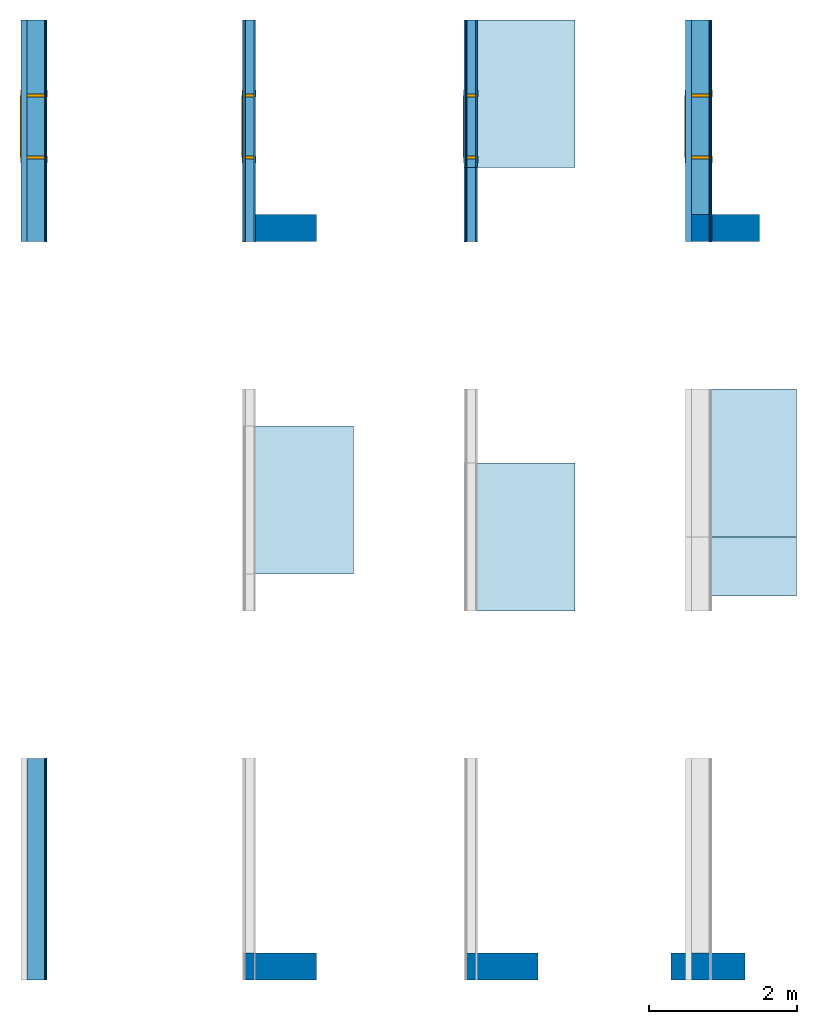
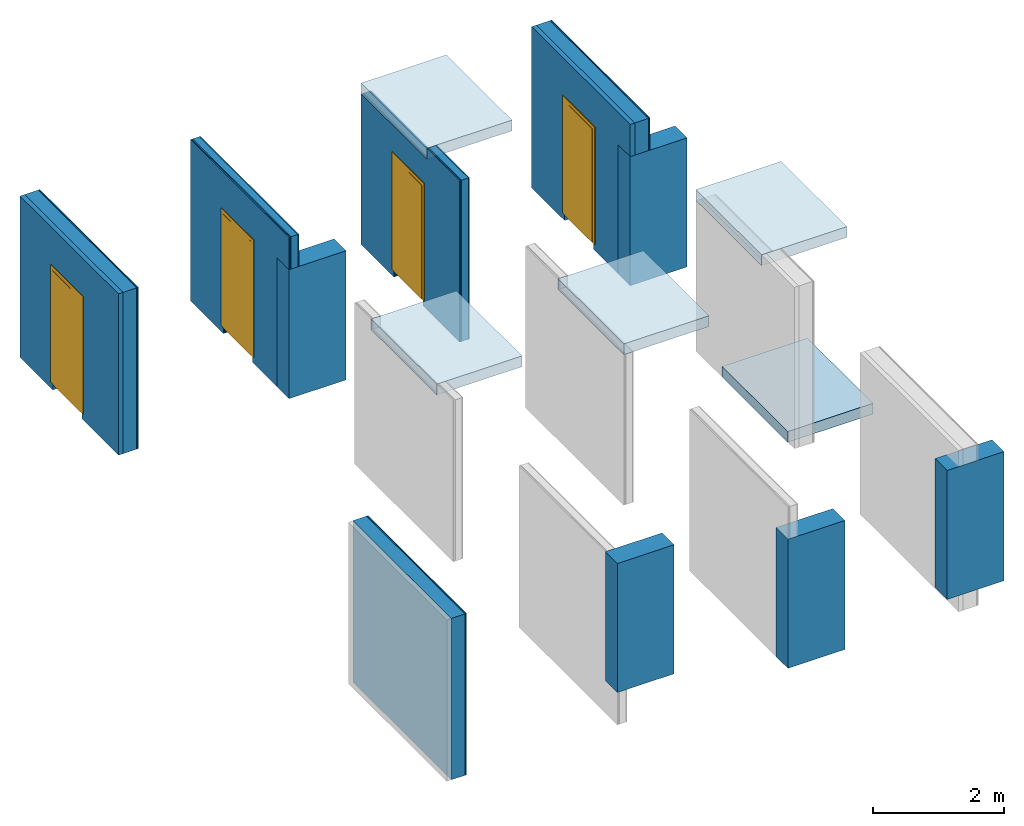
# One storey, part 1 of 2: 19 building element parts, 5 slabs, 5 walls, 4 doors, 4 openings, 5 elements without a shape of their own.
"""IFC4 building model written with IfcOpenShell, lengths in metres."""

from ifc_helpers import new_model, entity, si_unit, converted_unit, derived_unit, direction, frame, origin_with_axes, place, context, subcontext, project, spatial, polygons, source, transform, mapped, material, type_object, element, fill, aggregate, save


model = new_model("IFC4")

# Units and contexts
model_context = context("Model", 3, precision=1e-05, world=origin_with_axes(), true_north=direction((0.0, 1.0)))
body_context = subcontext(model_context, "Body", "Model", "MODEL_VIEW")
ifc_project = project(units=[si_unit("LENGTHUNIT", "METRE"), si_unit("AREAUNIT", "SQUARE_METRE"), si_unit("VOLUMEUNIT", "CUBIC_METRE"), converted_unit("PLANEANGLEUNIT", "DEGREE", entity("IfcPlaneAngleMeasure", 0.0174532925199), si_unit("PLANEANGLEUNIT", "RADIAN"), dimensions=[0, 0, 0, 0, 0, 0, 0]), converted_unit("TIMEUNIT", "Year", entity("IfcTimeMeasure", 31556926.0), si_unit("TIMEUNIT", "SECOND"), dimensions=[0, 0, 1, 0, 0, 0, 0]), si_unit("MASSUNIT", "GRAM", prefix="KILO"), si_unit("THERMODYNAMICTEMPERATUREUNIT", "DEGREE_CELSIUS"), si_unit("LUMINOUSINTENSITYUNIT", "LUMEN"), si_unit("ENERGYUNIT", "JOULE", prefix="MEGA"), derived_unit("THERMALCONDUCTANCEUNIT", [(si_unit("POWERUNIT", "WATT"), 1), (si_unit("LENGTHUNIT", "METRE"), -1), (si_unit("THERMODYNAMICTEMPERATUREUNIT", "KELVIN"), -1)]), derived_unit("SPECIFICHEATCAPACITYUNIT", [(si_unit("ENERGYUNIT", "JOULE"), 1), (si_unit("MASSUNIT", "GRAM", prefix="KILO"), -1), (si_unit("THERMODYNAMICTEMPERATUREUNIT", "KELVIN"), -1)]), derived_unit("MASSDENSITYUNIT", [(si_unit("MASSUNIT", "GRAM", prefix="KILO"), 1), (si_unit("VOLUMEUNIT", "CUBIC_METRE"), -1)])], contexts=[model_context])

# Site, building, storey
site_placement = place(None, origin_with_axes())
site = spatial("IfcSite", under=ifc_project, at=site_placement, CompositionType="ELEMENT")
building_placement = place(site_placement, origin_with_axes())
building = spatial("IfcBuilding", under=site, at=building_placement, CompositionType="ELEMENT")
storey_placement = place(building_placement, origin_with_axes())
storey = spatial("IfcBuildingStorey", under=building, at=storey_placement, Name="EG", CompositionType="ELEMENT", Elevation=0.0)

# Slabs
ifc_material_1 = material(Name="Stahlbeton-2")
slab_type = type_object("IfcSlabType", Name="Stahlbeton-2 200", PredefinedType="FLOOR")
for number, where, z_axis, x_axis, name in (
    (1, (9.0, 2.2, 0.05), (0.0, 0.0, 1.0), (1.0, 0.0, 0.0), "RD-002"),
    (2, (3.0, 2.5, 2.85), (0.0, 0.0, 1.0), (1.0, 0.0, 0.0), "RD-002"),
    (3, (6.0, 2.0, 2.85), (0.0, 0.0, 1.0), (1.0, 0.0, 0.0), "RD-002"),
    (4, (9.0, 3.0, 2.85), (0.0, 0.0, 1.0), (1.0, 0.0, 0.0), "RD-002"),
    (5, (6.0, 8.0, 2.85), (0.0, 0.0, 1.0), (1.0, 0.0, 0.0), "RD-002"),
):
    element("IfcSlab", number, at=place(storey_placement, frame(where, z_axis=z_axis, x_axis=x_axis)), inside=storey, type_object=slab_type, material=ifc_material_1, Name=name, PredefinedType="FLOOR", context=body_context, shape_type="Tessellation", body=[
        polygons([(0.0, 0.0, 0.0), (0.0, 0.0, -0.2), (1.5, 0.0, -0.2), (1.5, 0.0, 0.0), (0.0, 2.0, 0.0), (0.0, 2.0, -0.2), (1.5, 2.0, -0.2), (1.5, 2.0, 0.0)], [[[1, 2, 3, 4]], [[5, 6, 2, 1]], [[3, 2, 6, 7]], [[4, 3, 7, 8]], [[5, 1, 4, 8]], [[8, 7, 6, 5]]], closed=True),
    ])

# Door
door_type = type_object("IfcDoorType", Name="1-Fl 25", OperationType="SINGLE_SWING_RIGHT", PredefinedType="DOOR")
shared_shape_1 = source(origin_with_axes(), body_context, "Body", "Tessellation", [
    polygons([(0.4425, -0.36, 0.0), (0.4425, -0.025, 0.0), (0.4425, -0.025, 2.135), (0.4425, -0.36, 2.135), (0.4025, -0.36, 0.0), (0.4025, -0.025, 0.0), (0.4025, -0.025, 2.095), (0.0901, -0.025, 2.095), (0.0001, -0.025, 2.095), (-0.4025, -0.025, 2.095), (-0.4025, -0.025, 0.0), (-0.4425, -0.025, 0.0), (-0.4425, -0.025, 2.135), (-0.4425, -0.36, 2.135), (-0.4425, -0.36, 0.0), (-0.4025, -0.36, 0.0), (-0.4025, -0.36, 2.095), (0.0001, -0.36, 2.095), (0.0901, -0.36, 2.095), (0.4025, -0.36, 2.095)], [[[1, 2, 3, 4]], [[5, 6, 2, 1]], [[2, 6, 7, 8, 9, 10, 11, 12, 13, 3]], [[4, 3, 13, 14]], [[1, 4, 14, 15, 16, 17, 18, 19, 20, 5]], [[20, 7, 6, 5]], [[19, 8, 7, 20]], [[18, 9, 8, 19]], [[17, 10, 9, 18]], [[16, 11, 10, 17]], [[15, 12, 11, 16]], [[14, 13, 12, 15]]], closed=True),
    polygons([(0.4425, -0.025, 0.0), (0.4425, 0.01, 0.0), (0.4425, 0.01, 2.135), (0.4425, -0.025, 2.135), (0.4225, -0.025, 0.0), (0.4225, 0.01, 0.0), (0.4225, 0.01, 2.115), (0.0701, 0.01, 2.115), (0.0201, 0.01, 2.115), (-0.4225, 0.01, 2.115), (-0.4225, 0.01, 0.0), (-0.4425, 0.01, 0.0), (-0.4425, 0.01, 2.135), (-0.4425, -0.025, 2.135), (-0.4425, -0.025, 0.0), (-0.4225, -0.025, 0.0), (-0.4225, -0.025, 2.115), (0.0201, -0.025, 2.115), (0.0701, -0.025, 2.115), (0.4225, -0.025, 2.115)], [[[1, 2, 3, 4]], [[5, 6, 2, 1]], [[2, 6, 7, 8, 9, 10, 11, 12, 13, 3]], [[4, 3, 13, 14]], [[1, 4, 14, 15, 16, 17, 18, 19, 20, 5]], [[20, 7, 6, 5]], [[19, 8, 7, 20]], [[18, 9, 8, 19]], [[17, 10, 9, 18]], [[16, 11, 10, 17]], [[15, 12, 11, 16]], [[14, 13, 12, 15]]], closed=True),
    polygons([(0.4925, -0.36, 0.0), (0.4925, -0.35, 0.0), (0.4925, -0.35, 2.185), (0.4925, -0.36, 2.185), (0.4425, -0.36, 0.0), (0.4425, -0.35, 0.0), (0.4425, -0.35, 2.135), (-0.4425, -0.35, 2.135), (-0.4425, -0.35, 0.0), (-0.4925, -0.35, 0.0), (-0.4925, -0.35, 2.185), (-0.4925, -0.36, 2.185), (-0.4925, -0.36, 0.0), (-0.4425, -0.36, 0.0), (-0.4425, -0.36, 2.135), (0.4425, -0.36, 2.135)], [[[1, 2, 3, 4]], [[5, 6, 2, 1]], [[2, 6, 7, 8, 9, 10, 11, 3]], [[4, 3, 11, 12]], [[1, 4, 12, 13, 14, 15, 16, 5]], [[16, 7, 6, 5]], [[15, 8, 7, 16]], [[14, 9, 8, 15]], [[13, 10, 9, 14]], [[12, 11, 10, 13]]], closed=True),
    polygons([(0.4925, 0.0, 0.0), (0.4925, 0.01, 0.0), (0.4925, 0.01, 2.185), (0.4925, 0.0, 2.185), (0.4425, 0.0, 0.0), (0.4425, 0.01, 0.0), (0.4425, 0.01, 2.135), (-0.4425, 0.01, 2.135), (-0.4425, 0.01, 0.0), (-0.4925, 0.01, 0.0), (-0.4925, 0.01, 2.185), (-0.4925, 0.0, 2.185), (-0.4925, 0.0, 0.0), (-0.4425, 0.0, 0.0), (-0.4425, 0.0, 2.135), (0.4425, 0.0, 2.135)], [[[1, 2, 3, 4]], [[5, 6, 2, 1]], [[2, 6, 7, 8, 9, 10, 11, 3]], [[4, 3, 11, 12]], [[1, 4, 12, 13, 14, 15, 16, 5]], [[16, 7, 6, 5]], [[15, 8, 7, 16]], [[14, 9, 8, 15]], [[13, 10, 9, 14]], [[12, 11, 10, 13]]], closed=True),
    polygons([(0.4225, 0.015, 0.0), (-0.4225, 0.015, 0.0), (-0.4225, 0.015, 2.115), (0.4225, 0.015, 2.115), (0.4225, -0.025, 0.0), (-0.4225, -0.025, 0.0), (-0.4225, -0.025, 2.115), (0.4225, -0.025, 2.115)], [[[1, 2, 3, 4]], [[2, 1, 5, 6]], [[3, 2, 6, 7]], [[4, 3, 7, 8]], [[1, 4, 8, 5]], [[6, 5, 8, 7]]], closed=True),
])
wall_3_placement = place(storey_placement, frame((9.0, 10.0, -0.15), z_axis=(0.0, 0.0, 1.0), x_axis=(0.0, -1.0, 0.0)))
opening_1_placement = place(wall_3_placement, frame((1.4425, 0.0, 0.12), z_axis=(0.0, 0.0, 1.0), x_axis=(1.0, 0.0, 0.0)))
door_1_placement = place(opening_1_placement, frame((0.4425, 0.0, 0.0), z_axis=(0.0, 0.0, 1.0), x_axis=(-1.0, 0.0, 0.0)))
door_1 = element("IfcDoor", 6, at=door_1_placement, inside=storey, type_object=door_type, OverallHeight=5.105, OverallWidth=0.885, PredefinedType="DOOR", context=body_context, shape_type="MappedRepresentation", body=[
    mapped(shared_shape_1, transform((0.4425, 0.0, 0.0))),
])

wall_4_placement = place(storey_placement, frame((0.0, 10.0, -0.15), z_axis=(0.0, 0.0, 1.0), x_axis=(0.0, -1.0, 0.0)))
opening_2_placement = place(wall_4_placement, frame((1.4425, 0.0, 0.12), z_axis=(0.0, 0.0, 1.0), x_axis=(1.0, 0.0, 0.0)))
door_2_placement = place(opening_2_placement, frame((0.4425, 0.0, 0.0), z_axis=(0.0, 0.0, 1.0), x_axis=(-1.0, 0.0, 0.0)))
door_2 = element("IfcDoor", 7, at=door_2_placement, inside=storey, type_object=door_type, OverallHeight=5.105, OverallWidth=0.885, PredefinedType="DOOR", context=body_context, shape_type="MappedRepresentation", body=[
    mapped(shared_shape_1, transform((0.4425, 0.0, 0.0))),
])

shared_shape_2 = source(origin_with_axes(), body_context, "Body", "Tessellation", [
    polygons([(0.4425, -0.184, 0.0), (0.4425, -0.025, 0.0), (0.4425, -0.025, 2.135), (0.4425, -0.184, 2.135), (0.4025, -0.184, 0.0), (0.4025, -0.025, 0.0), (0.4025, -0.025, 2.095), (0.0901, -0.025, 2.095), (0.0001, -0.025, 2.095), (-0.4025, -0.025, 2.095), (-0.4025, -0.025, 0.0), (-0.4425, -0.025, 0.0), (-0.4425, -0.025, 2.135), (-0.4425, -0.184, 2.135), (-0.4425, -0.184, 0.0), (-0.4025, -0.184, 0.0), (-0.4025, -0.184, 2.095), (0.0001, -0.184, 2.095), (0.0901, -0.184, 2.095), (0.4025, -0.184, 2.095)], [[[1, 2, 3, 4]], [[5, 6, 2, 1]], [[2, 6, 7, 8, 9, 10, 11, 12, 13, 3]], [[4, 3, 13, 14]], [[1, 4, 14, 15, 16, 17, 18, 19, 20, 5]], [[20, 7, 6, 5]], [[19, 8, 7, 20]], [[18, 9, 8, 19]], [[17, 10, 9, 18]], [[16, 11, 10, 17]], [[15, 12, 11, 16]], [[14, 13, 12, 15]]], closed=True),
    polygons([(0.4425, -0.025, 0.0), (0.4425, 0.01, 0.0), (0.4425, 0.01, 2.135), (0.4425, -0.025, 2.135), (0.4225, -0.025, 0.0), (0.4225, 0.01, 0.0), (0.4225, 0.01, 2.115), (0.0701, 0.01, 2.115), (0.0201, 0.01, 2.115), (-0.4225, 0.01, 2.115), (-0.4225, 0.01, 0.0), (-0.4425, 0.01, 0.0), (-0.4425, 0.01, 2.135), (-0.4425, -0.025, 2.135), (-0.4425, -0.025, 0.0), (-0.4225, -0.025, 0.0), (-0.4225, -0.025, 2.115), (0.0201, -0.025, 2.115), (0.0701, -0.025, 2.115), (0.4225, -0.025, 2.115)], [[[1, 2, 3, 4]], [[5, 6, 2, 1]], [[2, 6, 7, 8, 9, 10, 11, 12, 13, 3]], [[4, 3, 13, 14]], [[1, 4, 14, 15, 16, 17, 18, 19, 20, 5]], [[20, 7, 6, 5]], [[19, 8, 7, 20]], [[18, 9, 8, 19]], [[17, 10, 9, 18]], [[16, 11, 10, 17]], [[15, 12, 11, 16]], [[14, 13, 12, 15]]], closed=True),
    polygons([(0.4925, -0.184, 0.0), (0.4925, -0.174, 0.0), (0.4925, -0.174, 2.185), (0.4925, -0.184, 2.185), (0.4425, -0.184, 0.0), (0.4425, -0.174, 0.0), (0.4425, -0.174, 2.135), (-0.4425, -0.174, 2.135), (-0.4425, -0.174, 0.0), (-0.4925, -0.174, 0.0), (-0.4925, -0.174, 2.185), (-0.4925, -0.184, 2.185), (-0.4925, -0.184, 0.0), (-0.4425, -0.184, 0.0), (-0.4425, -0.184, 2.135), (0.4425, -0.184, 2.135)], [[[1, 2, 3, 4]], [[5, 6, 2, 1]], [[2, 6, 7, 8, 9, 10, 11, 3]], [[4, 3, 11, 12]], [[1, 4, 12, 13, 14, 15, 16, 5]], [[16, 7, 6, 5]], [[15, 8, 7, 16]], [[14, 9, 8, 15]], [[13, 10, 9, 14]], [[12, 11, 10, 13]]], closed=True),
    polygons([(0.4925, 0.0, 0.0), (0.4925, 0.01, 0.0), (0.4925, 0.01, 2.185), (0.4925, 0.0, 2.185), (0.4425, 0.0, 0.0), (0.4425, 0.01, 0.0), (0.4425, 0.01, 2.135), (-0.4425, 0.01, 2.135), (-0.4425, 0.01, 0.0), (-0.4925, 0.01, 0.0), (-0.4925, 0.01, 2.185), (-0.4925, 0.0, 2.185), (-0.4925, 0.0, 0.0), (-0.4425, 0.0, 0.0), (-0.4425, 0.0, 2.135), (0.4425, 0.0, 2.135)], [[[1, 2, 3, 4]], [[5, 6, 2, 1]], [[2, 6, 7, 8, 9, 10, 11, 3]], [[4, 3, 11, 12]], [[1, 4, 12, 13, 14, 15, 16, 5]], [[16, 7, 6, 5]], [[15, 8, 7, 16]], [[14, 9, 8, 15]], [[13, 10, 9, 14]], [[12, 11, 10, 13]]], closed=True),
    polygons([(0.4225, 0.015, 0.0), (-0.4225, 0.015, 0.0), (-0.4225, 0.015, 2.115), (0.4225, 0.015, 2.115), (0.4225, -0.025, 0.0), (-0.4225, -0.025, 0.0), (-0.4225, -0.025, 2.115), (0.4225, -0.025, 2.115)], [[[1, 2, 3, 4]], [[2, 1, 5, 6]], [[3, 2, 6, 7]], [[4, 3, 7, 8]], [[1, 4, 8, 5]], [[6, 5, 8, 7]]], closed=True),
])
wall_5_placement = place(storey_placement, frame((3.0, 10.0, -0.15), z_axis=(0.0, 0.0, 1.0), x_axis=(0.0, -1.0, 0.0)))
opening_3_placement = place(wall_5_placement, frame((1.4425, 0.0, 0.12), z_axis=(0.0, 0.0, 1.0), x_axis=(1.0, 0.0, 0.0)))
door_3_placement = place(opening_3_placement, frame((0.4425, 0.0, 0.0), z_axis=(0.0, 0.0, 1.0), x_axis=(-1.0, 0.0, 0.0)))
door_3 = element("IfcDoor", 8, at=door_3_placement, inside=storey, type_object=door_type, OverallHeight=5.105, OverallWidth=0.885, PredefinedType="DOOR", context=body_context, shape_type="MappedRepresentation", body=[
    mapped(shared_shape_2, transform((0.4425, 0.0, 0.0))),
])

wall_6_placement = place(storey_placement, frame((6.0, 10.0, -0.15), z_axis=(0.0, 0.0, 1.0), x_axis=(0.0, -1.0, 0.0)))
opening_4_placement = place(wall_6_placement, frame((1.4425, 0.0, 0.12), z_axis=(0.0, 0.0, 1.0), x_axis=(1.0, 0.0, 0.0)))
door_4_placement = place(opening_4_placement, frame((0.4425, 0.0, 0.0), z_axis=(0.0, 0.0, 1.0), x_axis=(-1.0, 0.0, 0.0)))
door_4 = element("IfcDoor", 9, at=door_4_placement, inside=storey, type_object=door_type, OverallHeight=5.105, OverallWidth=0.885, PredefinedType="DOOR", context=body_context, shape_type="MappedRepresentation", body=[
    mapped(shared_shape_2, transform((0.4425, 0.0, 0.0))),
])

# Walls
wall_type_1 = type_object("IfcWallType", Name="Stahlbeton-2 365", PredefinedType="ELEMENTEDWALL")
wall_1_placement = place(storey_placement, frame((9.8, -3.0, 0.15), z_axis=(0.0, 0.0, 1.0), x_axis=(-1.0, 0.0, 0.0)))
element("IfcWall", 10, at=wall_1_placement, inside=storey, type_object=wall_type_1, material=ifc_material_1, Name="Wand-012", PredefinedType="ELEMENTEDWALL", context=body_context, shape_type="Tessellation", body=[
    polygons([(0.0, -0.365, 2.4), (1.0, -0.365, 2.4), (1.0, 0.0, 2.4), (0.0, 0.0, 2.4), (0.0, -0.365, 0.0), (1.0, -0.365, 0.0), (1.0, 0.0, 0.0), (0.0, 0.0, 0.0)], [[[1, 2, 3, 4]], [[5, 6, 2, 1]], [[3, 2, 6, 7]], [[4, 3, 7, 8]], [[5, 1, 4, 8]], [[8, 7, 6, 5]]], closed=True),
])
for number, where, z_axis, x_axis, name in (
    (11, (4.0, -3.0, 0.45), (0.0, 0.0, 1.0), (-1.0, 0.0, 0.0), "Wand-012"),
    (12, (7.0, -3.0, -0.15), (0.0, 0.0, 1.0), (-1.0, 0.0, 0.0), "Wand-012"),
    (13, (4.0, 7.0, -0.15), (0.0, 0.0, 1.0), (-1.0, 0.0, 0.0), "Wand-012"),
    (14, (10.0, 7.0, -0.15), (0.0, 0.0, 1.0), (-1.0, 0.0, 0.0), "Wand-012"),
):
    element("IfcWall", number, at=place(storey_placement, frame(where, z_axis=z_axis, x_axis=x_axis)), inside=storey, type_object=wall_type_1, material=ifc_material_1, Name=name, PredefinedType="ELEMENTEDWALL", context=body_context, shape_type="Tessellation", body=[
        polygons([(1.0, -0.365, 2.4), (1.0, 0.0, 2.4), (0.0, 0.0, 2.4), (0.0, -0.365, 2.4), (1.0, -0.365, 0.0), (1.0, 0.0, 0.0), (0.0, 0.0, 0.0), (0.0, -0.365, 0.0)], [[[1, 2, 3, 4]], [[2, 1, 5, 6]], [[2, 6, 7, 3]], [[8, 4, 3, 7]], [[5, 1, 4, 8]], [[6, 5, 8, 7]]], closed=True),
    ])

# Wall, building element parts
wall_type_2 = type_object("IfcWallType", PredefinedType="NOTDEFINED")
wall_2_placement = place(storey_placement, frame((0.0, 0.0, -0.15), z_axis=(0.0, 0.0, 1.0), x_axis=(0.0, -1.0, 0.0)))
wall_2 = element("IfcWall", 15, at=wall_2_placement, inside=storey, type_object=wall_type_2, Name="Wand-011", PredefinedType="NOTDEFINED")
ifc_material_2 = material(Name="Gipskarton vertikal (1)-10")
building_element_part_1_placement = place(wall_2_placement, origin_with_axes())
building_element_part_1 = element("IfcBuildingElementPart", 16, at=building_element_part_1_placement, material=ifc_material_2, Name="Gipskarton vertikal (1)-10", context=body_context, shape_type="Tessellation", body=[
    polygons([(3.0, 0.35, 0.0), (3.0, 0.335, 0.0), (0.0, 0.335, 0.0), (0.0, 0.35, 0.0), (3.0, 0.35, 3.0), (3.0, 0.335, 3.0), (0.0, 0.335, 3.0), (0.0, 0.35, 3.0)], [[[1, 2, 3, 4]], [[1, 5, 6, 2]], [[2, 6, 7, 3]], [[4, 3, 7, 8]], [[5, 1, 4, 8]], [[6, 5, 8, 7]]], closed=True),
])
ifc_material_3 = material(Name="OSB (1)-10")
building_element_part_2_placement = place(wall_2_placement, origin_with_axes())
building_element_part_2 = element("IfcBuildingElementPart", 17, at=building_element_part_2_placement, material=ifc_material_3, Name="OSB (1)-10", context=body_context, shape_type="Tessellation", body=[
    polygons([(3.0, 0.335, 0.0), (3.0, 0.32, 0.0), (0.0, 0.32, 0.0), (0.0, 0.335, 0.0), (3.0, 0.335, 3.0), (3.0, 0.32, 3.0), (0.0, 0.32, 3.0), (0.0, 0.335, 3.0)], [[[1, 2, 3, 4]], [[1, 5, 6, 2]], [[2, 6, 7, 3]], [[4, 3, 7, 8]], [[5, 1, 4, 8]], [[6, 5, 8, 7]]], closed=True),
])
ifc_material_4 = material(Name="(1)-10")
building_element_part_3_placement = place(wall_2_placement, origin_with_axes())
building_element_part_3 = element("IfcBuildingElementPart", 18, at=building_element_part_3_placement, material=ifc_material_4, Name="(1)-10", context=body_context, shape_type="Tessellation", body=[
    polygons([(3.0, 0.32, 0.0), (3.0, 0.08, 0.0), (0.0, 0.08, 0.0), (0.0, 0.32, 0.0), (3.0, 0.32, 3.0), (3.0, 0.08, 3.0), (0.0, 0.08, 3.0), (0.0, 0.32, 3.0)], [[[1, 2, 3, 4]], [[1, 5, 6, 2]], [[2, 6, 7, 3]], [[4, 3, 7, 8]], [[5, 1, 4, 8]], [[6, 5, 8, 7]]], closed=True),
])
aggregate(wall_2, [building_element_part_1, building_element_part_2, building_element_part_3])

# Wall, opening
wall_3 = element("IfcWall", 19, at=wall_3_placement, inside=storey, type_object=wall_type_2, Name="Wand-011", PredefinedType="NOTDEFINED")
opening_1 = element("IfcOpeningElement", 20, at=opening_1_placement, cuts=wall_3, context=body_context, identifier="Reference", shape_type="Tessellation", body=[
    polygons([(-0.4425, 0.35, 2.135), (-0.4425, 0.35, -2.97), (-0.4425, -0.7, -2.97), (-0.4425, -0.7, 2.135), (0.4425, 0.35, 2.135), (0.4425, 0.35, -2.97), (0.4425, -0.7, -2.97), (0.4425, -0.7, 2.135)], [[[1, 2, 3, 4]], [[1, 5, 6, 2]], [[2, 6, 7, 3]], [[4, 3, 7, 8]], [[5, 1, 4, 8]], [[6, 5, 8, 7]]], closed=True),
])

fill(opening_1, door_1)

# Building element part
building_element_part_4_placement = place(wall_3_placement, origin_with_axes())
building_element_part_4 = element("IfcBuildingElementPart", 21, at=building_element_part_4_placement, material=ifc_material_2, Name="Gipskarton vertikal (1)-10", context=body_context, shape_type="Tessellation", body=[
    polygons([(1.885, 0.35, 0.0), (1.885, 0.35, 2.255), (1.0, 0.35, 2.255), (1.0, 0.35, 0.0), (0.0, 0.35, 0.0), (0.0, 0.35, 3.0), (3.0, 0.35, 3.0), (3.0, 0.35, 2.4), (2.635, 0.35, 2.4), (2.635, 0.35, 0.0), (1.885, 0.335, 0.0), (1.885, 0.335, 2.255), (1.0, 0.335, 2.255), (1.0, 0.335, 0.0), (0.0, 0.335, 0.0), (0.0, 0.335, 3.0), (3.0, 0.335, 3.0), (3.0, 0.335, 2.4), (2.635, 0.335, 2.4), (2.635, 0.335, 0.0)], [[[1, 2, 3, 4, 5, 6, 7, 8, 9, 10]], [[2, 1, 11, 12]], [[3, 2, 12, 13]], [[4, 3, 13, 14]], [[4, 14, 15, 5]], [[6, 5, 15, 16]], [[17, 7, 6, 16]], [[8, 7, 17, 18]], [[8, 18, 19, 9]], [[9, 19, 20, 10]], [[11, 1, 10, 20]], [[12, 11, 20, 19, 18, 17, 16, 15, 14, 13]]], closed=True),
])

building_element_part_5_placement = place(wall_3_placement, origin_with_axes())
building_element_part_5 = element("IfcBuildingElementPart", 22, at=building_element_part_5_placement, material=ifc_material_3, Name="OSB (1)-10", context=body_context, shape_type="Tessellation", body=[
    polygons([(1.885, 0.335, 0.0), (1.885, 0.335, 2.255), (1.0, 0.335, 2.255), (1.0, 0.335, 0.0), (0.0, 0.335, 0.0), (0.0, 0.335, 3.0), (3.0, 0.335, 3.0), (3.0, 0.335, 2.4), (2.635, 0.335, 2.4), (2.635, 0.335, 0.0), (1.885, 0.32, 0.0), (1.885, 0.32, 2.255), (1.0, 0.32, 2.255), (1.0, 0.32, 0.0), (0.0, 0.32, 0.0), (0.0, 0.32, 3.0), (3.0, 0.32, 3.0), (3.0, 0.32, 2.4), (2.635, 0.32, 2.4), (2.635, 0.32, 0.0)], [[[1, 2, 3, 4, 5, 6, 7, 8, 9, 10]], [[2, 1, 11, 12]], [[3, 2, 12, 13]], [[4, 3, 13, 14]], [[4, 14, 15, 5]], [[6, 5, 15, 16]], [[17, 7, 6, 16]], [[8, 7, 17, 18]], [[8, 18, 19, 9]], [[9, 19, 20, 10]], [[11, 1, 10, 20]], [[12, 11, 20, 19, 18, 17, 16, 15, 14, 13]]], closed=True),
])

building_element_part_6_placement = place(wall_3_placement, origin_with_axes())
building_element_part_6 = element("IfcBuildingElementPart", 23, at=building_element_part_6_placement, material=ifc_material_4, Name="(1)-10", context=body_context, shape_type="Tessellation", body=[
    polygons([(1.885, 0.32, 0.0), (1.885, 0.32, 2.255), (1.0, 0.32, 2.255), (1.0, 0.32, 0.0), (0.0, 0.32, 0.0), (0.0, 0.32, 3.0), (3.0, 0.32, 3.0), (3.0, 0.32, 2.4), (2.635, 0.32, 2.4), (2.635, 0.32, 0.0), (1.885, 0.08, 0.0), (1.885, 0.08, 2.255), (1.0, 0.08, 2.255), (1.0, 0.08, 0.0), (0.0, 0.08, 0.0), (0.0, 0.08, 3.0), (3.0, 0.08, 3.0), (3.0, 0.08, 2.4), (2.635, 0.08, 2.4), (2.635, 0.08, 0.0)], [[[1, 2, 3, 4, 5, 6, 7, 8, 9, 10]], [[2, 1, 11, 12]], [[3, 2, 12, 13]], [[4, 3, 13, 14]], [[4, 14, 15, 5]], [[6, 5, 15, 16]], [[17, 7, 6, 16]], [[8, 7, 17, 18]], [[8, 18, 19, 9]], [[9, 19, 20, 10]], [[11, 1, 10, 20]], [[12, 11, 20, 19, 18, 17, 16, 15, 14, 13]]], closed=True),
])

ifc_material_5 = material(Name="Mineralwolle (1)-10")
building_element_part_7_placement = place(wall_3_placement, origin_with_axes())
building_element_part_7 = element("IfcBuildingElementPart", 24, at=building_element_part_7_placement, material=ifc_material_5, Name="Mineralwolle (1)-10", context=body_context, shape_type="Tessellation", body=[
    polygons([(1.885, 0.08, 0.0), (1.885, 0.08, 2.255), (1.0, 0.08, 2.255), (1.0, 0.08, 0.0), (0.0, 0.08, 0.0), (0.0, 0.08, 3.0), (3.0, 0.08, 3.0), (3.0, 0.08, 2.4), (2.635, 0.08, 2.4), (2.635, 0.08, 0.0), (1.885, 0.0, 0.0), (1.885, 0.0, 2.255), (1.0, 0.0, 2.255), (1.0, 0.0, 0.0), (0.0, 0.0, 0.0), (0.0, 0.0, 3.0), (3.0, 0.0, 3.0), (3.0, 0.0, 2.4), (2.635, 0.0, 2.4), (2.635, 0.0, 0.0)], [[[1, 2, 3, 4, 5, 6, 7, 8, 9, 10]], [[2, 1, 11, 12]], [[3, 2, 12, 13]], [[4, 3, 13, 14]], [[4, 14, 15, 5]], [[6, 5, 15, 16]], [[17, 7, 6, 16]], [[8, 7, 17, 18]], [[8, 18, 19, 9]], [[9, 19, 20, 10]], [[11, 1, 10, 20]], [[12, 11, 20, 19, 18, 17, 16, 15, 14, 13]]], closed=True),
])

aggregate(wall_3, [building_element_part_4, building_element_part_5, building_element_part_6, building_element_part_7])

# Wall, opening
wall_4 = element("IfcWall", 25, at=wall_4_placement, inside=storey, type_object=wall_type_2, Name="Wand-011", PredefinedType="NOTDEFINED")
opening_2 = element("IfcOpeningElement", 26, at=opening_2_placement, cuts=wall_4, context=body_context, identifier="Reference", shape_type="Tessellation", body=[
    polygons([(-0.4425, 0.35, 2.135), (-0.4425, 0.35, -2.97), (-0.4425, -0.7, -2.97), (-0.4425, -0.7, 2.135), (0.4425, 0.35, 2.135), (0.4425, 0.35, -2.97), (0.4425, -0.7, -2.97), (0.4425, -0.7, 2.135)], [[[1, 2, 3, 4]], [[1, 5, 6, 2]], [[2, 6, 7, 3]], [[4, 3, 7, 8]], [[5, 1, 4, 8]], [[6, 5, 8, 7]]], closed=True),
])

fill(opening_2, door_2)

# Building element part
building_element_part_8_placement = place(wall_4_placement, origin_with_axes())
building_element_part_8 = element("IfcBuildingElementPart", 27, at=building_element_part_8_placement, material=ifc_material_2, Name="Gipskarton vertikal (1)-10", context=body_context, shape_type="Tessellation", body=[
    polygons([(1.885, 0.35, 0.0), (1.885, 0.35, 2.255), (1.0, 0.35, 2.255), (1.0, 0.35, 0.0), (0.0, 0.35, 0.0), (0.0, 0.35, 3.0), (3.0, 0.35, 3.0), (3.0, 0.35, 0.0), (1.885, 0.335, 0.0), (1.885, 0.335, 2.255), (1.0, 0.335, 2.255), (1.0, 0.335, 0.0), (0.0, 0.335, 0.0), (0.0, 0.335, 3.0), (3.0, 0.335, 3.0), (3.0, 0.335, 0.0)], [[[1, 2, 3, 4, 5, 6, 7, 8]], [[2, 1, 9, 10]], [[3, 2, 10, 11]], [[4, 3, 11, 12]], [[4, 12, 13, 5]], [[13, 14, 6, 5]], [[7, 6, 14, 15]], [[7, 15, 16, 8]], [[9, 1, 8, 16]], [[10, 9, 16, 15, 14, 13, 12, 11]]], closed=True),
])

building_element_part_9_placement = place(wall_4_placement, origin_with_axes())
building_element_part_9 = element("IfcBuildingElementPart", 28, at=building_element_part_9_placement, material=ifc_material_3, Name="OSB (1)-10", context=body_context, shape_type="Tessellation", body=[
    polygons([(1.885, 0.335, 0.0), (1.885, 0.335, 2.255), (1.0, 0.335, 2.255), (1.0, 0.335, 0.0), (0.0, 0.335, 0.0), (0.0, 0.335, 3.0), (3.0, 0.335, 3.0), (3.0, 0.335, 0.0), (1.885, 0.32, 0.0), (1.885, 0.32, 2.255), (1.0, 0.32, 2.255), (1.0, 0.32, 0.0), (0.0, 0.32, 0.0), (0.0, 0.32, 3.0), (3.0, 0.32, 3.0), (3.0, 0.32, 0.0)], [[[1, 2, 3, 4, 5, 6, 7, 8]], [[2, 1, 9, 10]], [[3, 2, 10, 11]], [[4, 3, 11, 12]], [[4, 12, 13, 5]], [[13, 14, 6, 5]], [[7, 6, 14, 15]], [[7, 15, 16, 8]], [[9, 1, 8, 16]], [[10, 9, 16, 15, 14, 13, 12, 11]]], closed=True),
])

building_element_part_10_placement = place(wall_4_placement, origin_with_axes())
building_element_part_10 = element("IfcBuildingElementPart", 29, at=building_element_part_10_placement, material=ifc_material_4, Name="(1)-10", context=body_context, shape_type="Tessellation", body=[
    polygons([(1.885, 0.32, 0.0), (1.885, 0.32, 2.255), (1.0, 0.32, 2.255), (1.0, 0.32, 0.0), (0.0, 0.32, 0.0), (0.0, 0.32, 3.0), (3.0, 0.32, 3.0), (3.0, 0.32, 0.0), (1.885, 0.08, 0.0), (1.885, 0.08, 2.255), (1.0, 0.08, 2.255), (1.0, 0.08, 0.0), (0.0, 0.08, 0.0), (0.0, 0.08, 3.0), (3.0, 0.08, 3.0), (3.0, 0.08, 0.0)], [[[1, 2, 3, 4, 5, 6, 7, 8]], [[2, 1, 9, 10]], [[3, 2, 10, 11]], [[4, 3, 11, 12]], [[4, 12, 13, 5]], [[13, 14, 6, 5]], [[7, 6, 14, 15]], [[7, 15, 16, 8]], [[9, 1, 8, 16]], [[10, 9, 16, 15, 14, 13, 12, 11]]], closed=True),
])

building_element_part_11_placement = place(wall_4_placement, origin_with_axes())
building_element_part_11 = element("IfcBuildingElementPart", 30, at=building_element_part_11_placement, material=ifc_material_5, Name="Mineralwolle (1)-10", context=body_context, shape_type="Tessellation", body=[
    polygons([(1.885, 0.08, 0.0), (1.885, 0.08, 2.255), (1.0, 0.08, 2.255), (1.0, 0.08, 0.0), (0.0, 0.08, 0.0), (0.0, 0.08, 3.0), (3.0, 0.08, 3.0), (3.0, 0.08, 0.0), (1.885, 0.0, 0.0), (1.885, 0.0, 2.255), (1.0, 0.0, 2.255), (1.0, 0.0, 0.0), (0.0, 0.0, 0.0), (0.0, 0.0, 3.0), (3.0, 0.0, 3.0), (3.0, 0.0, 0.0)], [[[1, 2, 3, 4, 5, 6, 7, 8]], [[2, 1, 9, 10]], [[3, 2, 10, 11]], [[4, 3, 11, 12]], [[4, 12, 13, 5]], [[13, 14, 6, 5]], [[7, 6, 14, 15]], [[7, 15, 16, 8]], [[9, 1, 8, 16]], [[10, 9, 16, 15, 14, 13, 12, 11]]], closed=True),
])

aggregate(wall_4, [building_element_part_8, building_element_part_9, building_element_part_10, building_element_part_11])

# Wall, opening
wall_type_3 = type_object("IfcWallType", PredefinedType="NOTDEFINED")
wall_5 = element("IfcWall", 31, at=wall_5_placement, inside=storey, type_object=wall_type_3, Name="Wand-011", PredefinedType="NOTDEFINED")
opening_3 = element("IfcOpeningElement", 32, at=opening_3_placement, cuts=wall_5, context=body_context, identifier="Reference", shape_type="Tessellation", body=[
    polygons([(-0.4425, 0.174, 2.135), (-0.4425, 0.174, -2.97), (-0.4425, -0.348, -2.97), (-0.4425, -0.348, 2.135), (0.4425, 0.174, 2.135), (0.4425, 0.174, -2.97), (0.4425, -0.348, -2.97), (0.4425, -0.348, 2.135)], [[[1, 2, 3, 4]], [[1, 5, 6, 2]], [[2, 6, 7, 3]], [[4, 3, 7, 8]], [[5, 1, 4, 8]], [[6, 5, 8, 7]]], closed=True),
])

fill(opening_3, door_3)

# Building element part
ifc_material_6 = material(Name="Gipskarton vertikal (1)-10 (2)")
building_element_part_12_placement = place(wall_5_placement, origin_with_axes())
building_element_part_12 = element("IfcBuildingElementPart", 33, at=building_element_part_12_placement, material=ifc_material_6, Name="Gipskarton vertikal (1)-10 (2)", context=body_context, shape_type="Tessellation", body=[
    polygons([(1.885, 0.174, 0.0), (1.885, 0.174, 2.255), (1.0, 0.174, 2.255), (1.0, 0.174, 0.0), (0.0, 0.174, 0.0), (0.0, 0.174, 3.0), (3.0, 0.174, 3.0), (3.0, 0.174, 2.4), (2.635, 0.174, 2.4), (2.635, 0.174, 0.0), (1.885, 0.156, 0.0), (1.885, 0.156, 2.255), (1.0, 0.156, 2.255), (1.0, 0.156, 0.0), (0.0, 0.156, 0.0), (0.0, 0.156, 3.0), (3.0, 0.156, 3.0), (3.0, 0.156, 2.4), (2.635, 0.156, 2.4), (2.635, 0.156, 0.0)], [[[1, 2, 3, 4, 5, 6, 7, 8, 9, 10]], [[2, 1, 11, 12]], [[3, 2, 12, 13]], [[4, 3, 13, 14]], [[4, 14, 15, 5]], [[6, 5, 15, 16]], [[17, 7, 6, 16]], [[8, 7, 17, 18]], [[8, 18, 19, 9]], [[9, 19, 20, 10]], [[11, 1, 10, 20]], [[12, 11, 20, 19, 18, 17, 16, 15, 14, 13]]], closed=True),
])

ifc_material_7 = material(Name="(2)-10")
building_element_part_13_placement = place(wall_5_placement, origin_with_axes())
building_element_part_13 = element("IfcBuildingElementPart", 34, at=building_element_part_13_placement, material=ifc_material_7, Name="(2)-10", context=body_context, shape_type="Tessellation", body=[
    polygons([(1.885, 0.156, 0.0), (1.885, 0.156, 2.255), (1.0, 0.156, 2.255), (1.0, 0.156, 0.0), (0.0, 0.156, 0.0), (0.0, 0.156, 3.0), (3.0, 0.156, 3.0), (3.0, 0.156, 2.4), (2.635, 0.156, 2.4), (2.635, 0.156, 0.0), (1.885, 0.036, 0.0), (1.885, 0.036, 2.255), (1.0, 0.036, 2.255), (1.0, 0.036, 0.0), (0.0, 0.036, 0.0), (0.0, 0.036, 3.0), (3.0, 0.036, 3.0), (3.0, 0.036, 2.4), (2.635, 0.036, 2.4), (2.635, 0.036, 0.0)], [[[1, 2, 3, 4, 5, 6, 7, 8, 9, 10]], [[2, 1, 11, 12]], [[3, 2, 12, 13]], [[4, 3, 13, 14]], [[4, 14, 15, 5]], [[6, 5, 15, 16]], [[17, 7, 6, 16]], [[8, 7, 17, 18]], [[8, 18, 19, 9]], [[9, 19, 20, 10]], [[11, 1, 10, 20]], [[12, 11, 20, 19, 18, 17, 16, 15, 14, 13]]], closed=True),
])

building_element_part_14_placement = place(wall_5_placement, origin_with_axes())
building_element_part_14 = element("IfcBuildingElementPart", 35, at=building_element_part_14_placement, material=ifc_material_6, Name="Gipskarton vertikal (1)-10 (2)", context=body_context, shape_type="Tessellation", body=[
    polygons([(1.885, 0.036, 0.0), (1.885, 0.036, 2.255), (1.0, 0.036, 2.255), (1.0, 0.036, 0.0), (0.0, 0.036, 0.0), (0.0, 0.036, 3.0), (3.0, 0.036, 3.0), (3.0, 0.036, 2.4), (2.635, 0.036, 2.4), (2.635, 0.036, 0.0), (1.885, 0.018, 0.0), (1.885, 0.018, 2.255), (1.0, 0.018, 2.255), (1.0, 0.018, 0.0), (0.0, 0.018, 0.0), (0.0, 0.018, 3.0), (3.0, 0.018, 3.0), (3.0, 0.018, 2.4), (2.635, 0.018, 2.4), (2.635, 0.018, 0.0)], [[[1, 2, 3, 4, 5, 6, 7, 8, 9, 10]], [[2, 1, 11, 12]], [[3, 2, 12, 13]], [[4, 3, 13, 14]], [[4, 14, 15, 5]], [[6, 5, 15, 16]], [[17, 7, 6, 16]], [[8, 7, 17, 18]], [[8, 18, 19, 9]], [[9, 19, 20, 10]], [[11, 1, 10, 20]], [[12, 11, 20, 19, 18, 17, 16, 15, 14, 13]]], closed=True),
])

building_element_part_15_placement = place(wall_5_placement, origin_with_axes())
building_element_part_15 = element("IfcBuildingElementPart", 36, at=building_element_part_15_placement, material=ifc_material_6, Name="Gipskarton vertikal (1)-10 (2)", context=body_context, shape_type="Tessellation", body=[
    polygons([(1.885, 0.018, 0.0), (1.885, 0.018, 2.255), (1.0, 0.018, 2.255), (1.0, 0.018, 0.0), (0.0, 0.018, 0.0), (0.0, 0.018, 3.0), (3.0, 0.018, 3.0), (3.0, 0.018, 2.4), (2.635, 0.018, 2.4), (2.635, 0.018, 0.0), (1.885, 0.0, 0.0), (1.885, 0.0, 2.255), (1.0, 0.0, 2.255), (1.0, 0.0, 0.0), (0.0, 0.0, 0.0), (0.0, 0.0, 3.0), (3.0, 0.0, 3.0), (3.0, 0.0, 2.4), (2.635, 0.0, 2.4), (2.635, 0.0, 0.0)], [[[1, 2, 3, 4, 5, 6, 7, 8, 9, 10]], [[2, 1, 11, 12]], [[3, 2, 12, 13]], [[4, 3, 13, 14]], [[4, 14, 15, 5]], [[6, 5, 15, 16]], [[17, 7, 6, 16]], [[8, 7, 17, 18]], [[8, 18, 19, 9]], [[9, 19, 20, 10]], [[11, 1, 10, 20]], [[12, 11, 20, 19, 18, 17, 16, 15, 14, 13]]], closed=True),
])

aggregate(wall_5, [building_element_part_12, building_element_part_13, building_element_part_14, building_element_part_15])

# Wall, opening
wall_6 = element("IfcWall", 37, at=wall_6_placement, inside=storey, type_object=wall_type_3, Name="Wand-011", PredefinedType="NOTDEFINED")
opening_4 = element("IfcOpeningElement", 38, at=opening_4_placement, cuts=wall_6, context=body_context, identifier="Reference", shape_type="Tessellation", body=[
    polygons([(-0.4425, 0.174, 2.135), (-0.4425, 0.174, -2.97), (-0.4425, -0.348, -2.97), (-0.4425, -0.348, 2.135), (0.4425, 0.174, 2.135), (0.4425, 0.174, -2.97), (0.4425, -0.348, -2.97), (0.4425, -0.348, 2.135)], [[[1, 2, 3, 4]], [[1, 5, 6, 2]], [[2, 6, 7, 3]], [[4, 3, 7, 8]], [[5, 1, 4, 8]], [[6, 5, 8, 7]]], closed=True),
])

fill(opening_4, door_4)

# Building element part
building_element_part_16_placement = place(wall_6_placement, origin_with_axes())
building_element_part_16 = element("IfcBuildingElementPart", 39, at=building_element_part_16_placement, material=ifc_material_6, Name="Gipskarton vertikal (1)-10 (2)", context=body_context, shape_type="Tessellation", body=[
    polygons([(1.885, 0.174, 0.0), (1.885, 0.174, 2.255), (1.0, 0.174, 2.255), (1.0, 0.174, 0.0), (0.0, 0.174, 0.0), (0.0, 0.174, 2.8), (2.0, 0.174, 2.8), (2.0, 0.174, 3.0), (3.0, 0.174, 3.0), (3.0, 0.174, 0.0), (1.885, 0.156, 0.0), (1.885, 0.156, 2.255), (1.0, 0.156, 2.255), (1.0, 0.156, 0.0), (0.0, 0.156, 0.0), (0.0, 0.156, 2.8), (2.0, 0.156, 2.8), (2.0, 0.156, 3.0), (3.0, 0.156, 3.0), (3.0, 0.156, 0.0)], [[[1, 2, 3, 4, 5, 6, 7, 8, 9, 10]], [[2, 1, 11, 12]], [[3, 2, 12, 13]], [[4, 3, 13, 14]], [[4, 14, 15, 5]], [[6, 5, 15, 16]], [[6, 16, 17, 7]], [[8, 7, 17, 18]], [[18, 19, 9, 8]], [[10, 9, 19, 20]], [[11, 1, 10, 20]], [[12, 11, 20, 19, 18, 17, 16, 15, 14, 13]]], closed=True),
])

building_element_part_17_placement = place(wall_6_placement, origin_with_axes())
building_element_part_17 = element("IfcBuildingElementPart", 40, at=building_element_part_17_placement, material=ifc_material_7, Name="(2)-10", context=body_context, shape_type="Tessellation", body=[
    polygons([(1.885, 0.156, 0.0), (1.885, 0.156, 2.255), (1.0, 0.156, 2.255), (1.0, 0.156, 0.0), (0.0, 0.156, 0.0), (0.0, 0.156, 2.8), (2.0, 0.156, 2.8), (2.0, 0.156, 3.0), (3.0, 0.156, 3.0), (3.0, 0.156, 0.0), (1.885, 0.036, 0.0), (1.885, 0.036, 2.255), (1.0, 0.036, 2.255), (1.0, 0.036, 0.0), (0.0, 0.036, 0.0), (0.0, 0.036, 2.8), (2.0, 0.036, 2.8), (2.0, 0.036, 3.0), (3.0, 0.036, 3.0), (3.0, 0.036, 0.0)], [[[1, 2, 3, 4, 5, 6, 7, 8, 9, 10]], [[2, 1, 11, 12]], [[3, 2, 12, 13]], [[4, 3, 13, 14]], [[4, 14, 15, 5]], [[6, 5, 15, 16]], [[6, 16, 17, 7]], [[8, 7, 17, 18]], [[18, 19, 9, 8]], [[10, 9, 19, 20]], [[11, 1, 10, 20]], [[12, 11, 20, 19, 18, 17, 16, 15, 14, 13]]], closed=True),
])

building_element_part_18_placement = place(wall_6_placement, origin_with_axes())
building_element_part_18 = element("IfcBuildingElementPart", 41, at=building_element_part_18_placement, material=ifc_material_6, Name="Gipskarton vertikal (1)-10 (2)", context=body_context, shape_type="Tessellation", body=[
    polygons([(1.885, 0.036, 0.0), (1.885, 0.036, 2.255), (1.0, 0.036, 2.255), (1.0, 0.036, 0.0), (0.0, 0.036, 0.0), (0.0, 0.036, 2.8), (2.0, 0.036, 2.8), (2.0, 0.036, 3.0), (3.0, 0.036, 3.0), (3.0, 0.036, 0.0), (1.885, 0.018, 0.0), (1.885, 0.018, 2.255), (1.0, 0.018, 2.255), (1.0, 0.018, 0.0), (0.0, 0.018, 0.0), (0.0, 0.018, 2.8), (2.0, 0.018, 2.8), (2.0, 0.018, 3.0), (3.0, 0.018, 3.0), (3.0, 0.018, 0.0)], [[[1, 2, 3, 4, 5, 6, 7, 8, 9, 10]], [[2, 1, 11, 12]], [[3, 2, 12, 13]], [[4, 3, 13, 14]], [[4, 14, 15, 5]], [[6, 5, 15, 16]], [[6, 16, 17, 7]], [[8, 7, 17, 18]], [[18, 19, 9, 8]], [[10, 9, 19, 20]], [[11, 1, 10, 20]], [[12, 11, 20, 19, 18, 17, 16, 15, 14, 13]]], closed=True),
])

building_element_part_19_placement = place(wall_6_placement, origin_with_axes())
building_element_part_19 = element("IfcBuildingElementPart", 42, at=building_element_part_19_placement, material=ifc_material_6, Name="Gipskarton vertikal (1)-10 (2)", context=body_context, shape_type="Tessellation", body=[
    polygons([(1.885, 0.018, 0.0), (1.885, 0.018, 2.255), (1.0, 0.018, 2.255), (1.0, 0.018, 0.0), (0.0, 0.018, 0.0), (0.0, 0.018, 2.8), (2.0, 0.018, 2.8), (2.0, 0.018, 3.0), (3.0, 0.018, 3.0), (3.0, 0.018, 0.0), (1.885, 0.0, 0.0), (1.885, 0.0, 2.255), (1.0, 0.0, 2.255), (1.0, 0.0, 0.0), (0.0, 0.0, 0.0), (0.0, 0.0, 2.8), (2.0, 0.0, 2.8), (2.0, 0.0, 3.0), (3.0, 0.0, 3.0), (3.0, 0.0, 0.0)], [[[1, 2, 3, 4, 5, 6, 7, 8, 9, 10]], [[2, 1, 11, 12]], [[3, 2, 12, 13]], [[4, 3, 13, 14]], [[4, 14, 15, 5]], [[6, 5, 15, 16]], [[6, 16, 17, 7]], [[8, 7, 17, 18]], [[18, 19, 9, 8]], [[10, 9, 19, 20]], [[11, 1, 10, 20]], [[12, 11, 20, 19, 18, 17, 16, 15, 14, 13]]], closed=True),
])

aggregate(wall_6, [building_element_part_16, building_element_part_17, building_element_part_18, building_element_part_19])

save(model, "model.ifc")
